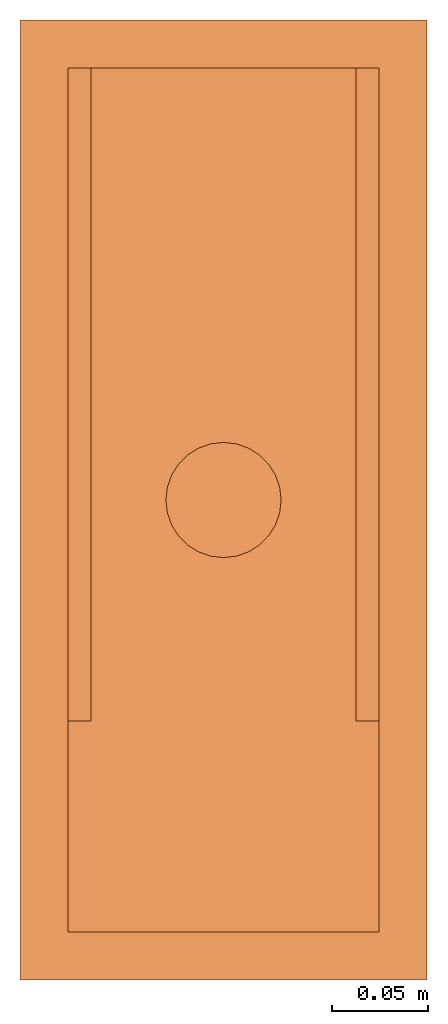
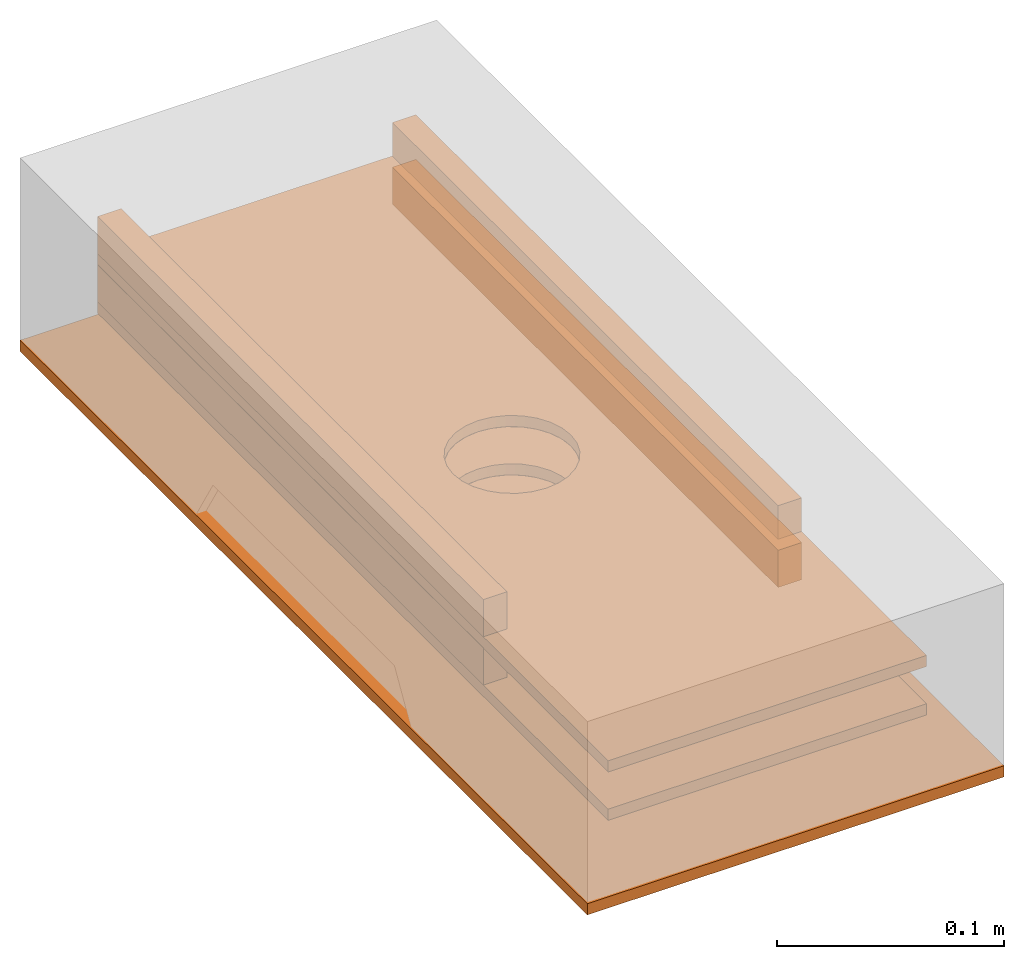
# One storey, part 1 of 2: 7 proxies.
"""IFC2X3 building model written with IfcOpenShell, lengths in millimetres."""

from ifc_helpers import new_model, si_unit, derived_unit, direction, frame, origin_with_axes, place, context, project, spatial, faceted_brep, source, transform, mapped, element, save


model = new_model("IFC2X3")

# Units and contexts
model_context = context("Model", 3, precision=1e-05, world=origin_with_axes(), true_north=direction((0.0, 1.0, 0.0)))
ifc_project = project(units=[si_unit("LENGTHUNIT", "METRE", prefix="MILLI"), si_unit("AREAUNIT", "SQUARE_METRE"), si_unit("SOLIDANGLEUNIT", "STERADIAN"), si_unit("PLANEANGLEUNIT", "RADIAN"), si_unit("TIMEUNIT", "SECOND"), si_unit("THERMODYNAMICTEMPERATUREUNIT", "DEGREE_CELSIUS"), si_unit("LUMINOUSINTENSITYUNIT", "LUMEN"), si_unit("MASSUNIT", "GRAM", prefix="KILO"), si_unit("VOLUMEUNIT", "CUBIC_METRE"), derived_unit("MASSDENSITYUNIT", [(si_unit("MASSUNIT", "GRAM", prefix="KILO"), 0), (si_unit("VOLUMEUNIT", "CUBIC_METRE"), -1)])], contexts=[model_context])

# Site, building, storey
site_placement = place(None, origin_with_axes())
site = spatial("IfcSite", under=ifc_project, at=site_placement, CompositionType="ELEMENT")
building_placement = place(site_placement, origin_with_axes())
building = spatial("IfcBuilding", under=site, at=building_placement, Name="Default Building", CompositionType="ELEMENT")
storey_placement = place(building_placement, origin_with_axes())
storey = spatial("IfcBuildingStorey", under=building, at=storey_placement, Name="Default Storey", CompositionType="ELEMENT")

# Proxies
shared_shape_1 = source(origin_with_axes(), model_context, "Body", "Brep", [
    faceted_brep([(0.0, -106.0, 0.0), (0.0, 106.0, -500.0), (0.0, 106.0, 0.0), (0.0, -106.0, -500.0), (6.0, -106.0, -500.0), (6.0, 106.0, 0.0), (6.0, 106.0, -500.0), (6.0, -106.0, 0.0)], [[[0, 1, 2]], [[1, 0, 3]], [[4, 5, 6]], [[5, 4, 7]], [[2, 6, 5]], [[6, 2, 1]], [[0, 5, 7]], [[5, 0, 2]], [[3, 7, 4]], [[7, 3, 0]], [[1, 4, 6]], [[4, 1, 3]]]),
])
proxy_1_placement = place(storey_placement, frame((1e-20, 0.0, -104.0), z_axis=(0.0, -1.0, 0.0), x_axis=(0.0, 0.0, 1.0)))
element("IfcBuildingElementProxy", 1, at=proxy_1_placement, inside=storey, ObjectType="General", context=model_context, shape_type="MappedRepresentation", body=[
    mapped(shared_shape_1, transform((0.0, 0.0, 0.0), scale=1.0)),
])
shared_shape_2 = source(origin_with_axes(), model_context, "Body", "Brep", [
    faceted_brep([(-81.0, -3.0, -225.0), (-81.0, -3.0, 225.0), (81.0, -3.0, 225.0), (81.0, -3.0, -225.0), (30.0, -3.0, 7.34788079488412e-15), (29.247837365454707, -3.0, 6.675628018689439), (27.02906603707257, -3.0, 13.01651217352675), (23.45494447404089, -3.0, 18.704694055762012), (18.704694055762, -3.0, 23.454944474040897), (13.016512173526738, -3.0, 27.029066037072578), (6.675628018689427, -3.0, 29.247837365454707), (-5.510910596163089e-15, -3.0, 30.0), (-6.675628018689437, -3.0, 29.247837365454707), (-13.016512173526749, -3.0, 27.02906603707257), (-18.704694055762012, -3.0, 23.45494447404089), (-23.454944474040904, -3.0, 18.70469405576199), (-27.029066037072575, -3.0, 13.01651217352674), (-29.24783736545471, -3.0, 6.675628018689415), (-30.0, -3.0, -3.67394039744206e-15), (-29.247837365454707, -3.0, -6.6756280186894355), (-27.02906603707257, -3.0, -13.016512173526747), (-23.45494447404089, -3.0, -18.70469405576201), (-18.704694055762005, -3.0, -23.454944474040897), (-13.016512173526742, -3.0, -27.029066037072575), (-6.67562801868943, -3.0, -29.247837365454707), (1.83697019872103e-15, -3.0, -30.0), (6.675628018689434, -3.0, -29.247837365454707), (13.016512173526745, -3.0, -27.029066037072575), (18.70469405576201, -3.0, -23.454944474040893), (23.454944474040893, -3.0, -18.704694055762005), (27.029066037072575, -3.0, -13.016512173526744), (29.247837365454707, -3.0, -6.675628018689432), (-81.0, 3.0, -225.0), (-81.0, 3.0, 225.0), (81.0, 3.0, 225.0), (81.0, 3.0, -225.0), (30.0, 3.0, 7.34788079488412e-15), (29.247837365454707, 3.0, 6.675628018689439), (27.02906603707257, 3.0, 13.01651217352675), (23.45494447404089, 3.0, 18.704694055762012), (18.704694055762, 3.0, 23.454944474040897), (13.016512173526738, 3.0, 27.029066037072578), (6.675628018689427, 3.0, 29.247837365454707), (-5.510910596163089e-15, 3.0, 30.0), (-6.675628018689437, 3.0, 29.247837365454707), (-13.016512173526749, 3.0, 27.02906603707257), (-18.704694055762012, 3.0, 23.45494447404089), (-23.454944474040904, 3.0, 18.70469405576199), (-27.029066037072575, 3.0, 13.01651217352674), (-29.24783736545471, 3.0, 6.675628018689415), (-30.0, 3.0, -3.67394039744206e-15), (-29.247837365454707, 3.0, -6.6756280186894355), (-27.02906603707257, 3.0, -13.016512173526747), (-23.45494447404089, 3.0, -18.70469405576201), (-18.704694055762005, 3.0, -23.454944474040897), (-13.016512173526742, 3.0, -27.029066037072575), (-6.67562801868943, 3.0, -29.247837365454707), (1.83697019872103e-15, 3.0, -30.0), (6.675628018689434, 3.0, -29.247837365454707), (13.016512173526745, 3.0, -27.029066037072575), (18.70469405576201, 3.0, -23.454944474040893), (23.454944474040893, 3.0, -18.704694055762005), (27.029066037072575, 3.0, -13.016512173526744), (29.247837365454707, 3.0, -6.675628018689432), (30.0, 3.0, 3.673940187178589e-15), (29.691041946411133, -3.0, 4.286857604980469), (30.0, -3.0, 3.673940187178589e-15), (29.691041946411133, 3.0, 4.286857604980469), (28.785158157348633, -3.0, 8.446757316589355), (28.785158157348633, 3.0, 8.446757316589355), (27.28719711303711, -3.0, 12.465845108032227), (27.28719711303711, 3.0, 12.465845108032227), (25.235445022583008, -3.0, 16.219356536865234), (25.235445022583008, 3.0, 16.219356536865234), (22.675521850585938, -3.0, 19.641361236572266), (22.675521850585938, 3.0, 19.641361236572266), (19.641361236572266, -3.0, 22.675521850585938), (19.641361236572266, 3.0, 22.675521850585938), (16.219356536865234, -3.0, 25.235445022583008), (16.219356536865234, 3.0, 25.235445022583008), (12.465845108032227, -3.0, 27.28719711303711), (12.465845108032227, 3.0, 27.28719711303711), (8.446757316589355, -3.0, 28.785158157348633), (8.446757316589355, 3.0, 28.785158157348633), (4.272773742675781, -3.0, 29.692628860473633), (4.272773742675781, 3.0, 29.692628860473633), (-5.510910704284357e-15, -3.0, 30.0), (-5.510910704284357e-15, 3.0, 30.0), (-4.272773742675781, -3.0, 29.692628860473633), (-4.272773742675781, 3.0, 29.692628860473633), (-8.446757316589355, -3.0, 28.785158157348633), (-8.446757316589355, 3.0, 28.785158157348633), (-12.465845108032227, -3.0, 27.28719711303711), (-12.465845108032227, 3.0, 27.28719711303711), (-16.219356536865234, -3.0, 25.235445022583008), (-16.219356536865234, 3.0, 25.235445022583008), (-19.641361236572266, -3.0, 22.675521850585938), (-19.641361236572266, 3.0, 22.675521850585938), (-22.675521850585938, -3.0, 19.641361236572266), (-22.675521850585938, 3.0, 19.641361236572266), (-25.235445022583008, -3.0, 16.219356536865234), (-25.235445022583008, 3.0, 16.219356536865234), (-27.28719711303711, -3.0, 12.465845108032227), (-27.28719711303711, 3.0, 12.465845108032227), (-28.785158157348633, -3.0, 8.446757316589355), (-28.785158157348633, 3.0, 8.446757316589355), (-29.691041946411133, -3.0, 4.286857604980469), (-29.691041946411133, 3.0, 4.286857604980469), (-30.0, -3.0, -3.673940187178589e-15), (-30.0, 3.0, -3.673940187178589e-15), (-29.691041946411133, -3.0, -4.286857604980469), (-29.691041946411133, 3.0, -4.286857604980469), (-28.785158157348633, -3.0, -8.446757316589355), (-28.785158157348633, 3.0, -8.446757316589355), (-27.28719711303711, -3.0, -12.465845108032227), (-27.28719711303711, 3.0, -12.465845108032227), (-25.235445022583008, -3.0, -16.219356536865234), (-25.235445022583008, 3.0, -16.219356536865234), (-22.675521850585938, -3.0, -19.641361236572266), (-22.675521850585938, 3.0, -19.641361236572266), (-19.641361236572266, -3.0, -22.675521850585938), (-19.641361236572266, 3.0, -22.675521850585938), (-16.219356536865234, -3.0, -25.235445022583008), (-16.219356536865234, 3.0, -25.235445022583008), (-12.465845108032227, -3.0, -27.28719711303711), (-12.465845108032227, 3.0, -27.28719711303711), (-8.446757316589355, -3.0, -28.785158157348633), (-8.446757316589355, 3.0, -28.785158157348633), (-4.272773742675781, -3.0, -29.692628860473633), (-4.272773742675781, 3.0, -29.692628860473633), (1.8369700935892946e-15, -3.0, -30.0), (1.8369700935892946e-15, 3.0, -30.0), (4.272773742675781, -3.0, -29.692628860473633), (4.272773742675781, 3.0, -29.692628860473633), (8.446757316589355, -3.0, -28.785158157348633), (8.446757316589355, 3.0, -28.785158157348633), (12.465845108032227, -3.0, -27.28719711303711), (12.465845108032227, 3.0, -27.28719711303711), (16.219356536865234, -3.0, -25.235445022583008), (16.219356536865234, 3.0, -25.235445022583008), (19.641361236572266, -3.0, -22.675521850585938), (19.641361236572266, 3.0, -22.675521850585938), (22.675521850585938, -3.0, -19.641361236572266), (22.675521850585938, 3.0, -19.641361236572266), (25.235445022583008, -3.0, -16.219356536865234), (25.235445022583008, 3.0, -16.219356536865234), (27.28719711303711, -3.0, -12.465845108032227), (27.28719711303711, 3.0, -12.465845108032227), (28.785158157348633, -3.0, -8.446757316589355), (28.785158157348633, 3.0, -8.446757316589355), (29.691041946411133, -3.0, -4.286857604980469), (29.691041946411133, 3.0, -4.286857604980469)], [[[0, 1, 2, 3], [4, 5, 6, 7, 8, 9, 10, 11, 12, 13, 14, 15, 16, 17, 18, 19, 20, 21, 22, 23, 24, 25, 26, 27, 28, 29, 30, 31]], [[32, 33, 34, 35], [36, 37, 38, 39, 40, 41, 42, 43, 44, 45, 46, 47, 48, 49, 50, 51, 52, 53, 54, 55, 56, 57, 58, 59, 60, 61, 62, 63]], [[64, 65, 66]], [[65, 64, 67]], [[67, 68, 65]], [[68, 67, 69]], [[69, 70, 68]], [[70, 69, 71]], [[71, 72, 70]], [[72, 71, 73]], [[73, 74, 72]], [[74, 73, 75]], [[75, 76, 74]], [[76, 75, 77]], [[77, 78, 76]], [[78, 77, 79]], [[79, 80, 78]], [[80, 79, 81]], [[81, 82, 80]], [[82, 81, 83]], [[83, 84, 82]], [[84, 83, 85]], [[85, 86, 84]], [[86, 85, 87]], [[87, 88, 86]], [[88, 87, 89]], [[89, 90, 88]], [[90, 89, 91]], [[91, 92, 90]], [[92, 91, 93]], [[93, 94, 92]], [[94, 93, 95]], [[95, 96, 94]], [[96, 95, 97]], [[97, 98, 96]], [[98, 97, 99]], [[99, 100, 98]], [[100, 99, 101]], [[101, 102, 100]], [[102, 101, 103]], [[103, 104, 102]], [[104, 103, 105]], [[105, 106, 104]], [[106, 105, 107]], [[107, 108, 106]], [[108, 107, 109]], [[109, 110, 108]], [[110, 109, 111]], [[111, 112, 110]], [[112, 111, 113]], [[113, 114, 112]], [[114, 113, 115]], [[115, 116, 114]], [[116, 115, 117]], [[117, 118, 116]], [[118, 117, 119]], [[119, 120, 118]], [[120, 119, 121]], [[121, 122, 120]], [[122, 121, 123]], [[123, 124, 122]], [[124, 123, 125]], [[125, 126, 124]], [[126, 125, 127]], [[127, 128, 126]], [[128, 127, 129]], [[129, 130, 128]], [[130, 129, 131]], [[131, 132, 130]], [[132, 131, 133]], [[133, 134, 132]], [[134, 133, 135]], [[135, 136, 134]], [[136, 135, 137]], [[137, 138, 136]], [[138, 137, 139]], [[139, 140, 138]], [[140, 139, 141]], [[141, 142, 140]], [[142, 141, 143]], [[143, 144, 142]], [[144, 143, 145]], [[145, 146, 144]], [[146, 145, 147]], [[147, 148, 146]], [[148, 147, 149]], [[149, 150, 148]], [[150, 149, 151]], [[151, 66, 150]], [[66, 151, 64]], [[1, 32, 33]], [[32, 1, 0]], [[2, 33, 34]], [[33, 2, 1]], [[3, 34, 35]], [[34, 3, 2]], [[0, 35, 32]], [[35, 0, 3]]]),
])
for number, where, z_axis, x_axis, name in (
    (2, (0.0, 250.0, -48.0), (0.0, -1.0, 0.0), (1.0, 0.0, 0.0), "BOARD-2"),
    (3, (0.0, 250.0, -74.0), (0.0, -1.0, 0.0), (1.0, 0.0, 0.0), "BOARD-2"),
):
    element("IfcBuildingElementProxy", number, at=place(storey_placement, frame(where, z_axis=z_axis, x_axis=x_axis)), inside=storey, Name=name, ObjectType="General", context=model_context, shape_type="MappedRepresentation", body=[
        mapped(shared_shape_2, transform((0.0, 0.0, 0.0), scale=1.0)),
    ])
shared_shape_3 = source(origin_with_axes(), model_context, "Body", "Brep", [
    faceted_brep([(0.0, -12.0, 0.0), (0.0, 0.0, -20.0), (0.0, 0.0, 0.0), (0.0, -12.0, -20.0), (340.0, -12.0, -20.0), (340.0, 0.0, 0.0), (340.0, 0.0, -20.0), (340.0, -12.0, 0.0)], [[[0, 1, 2]], [[1, 0, 3]], [[4, 5, 6]], [[5, 4, 7]], [[7, 2, 5]], [[2, 7, 0]], [[4, 0, 7]], [[0, 4, 3]], [[6, 3, 4]], [[3, 6, 1]], [[5, 1, 6]], [[1, 5, 2]]]),
])
for number, where, z_axis, x_axis, name in (
    (4, (-69.0, 475.0, -51.0), (0.0, 0.0, 1.0), (0.0, -1.0, 0.0), "02"),
    (5, (81.0, 475.0, -51.0), (0.0, 0.0, 1.0), (0.0, -1.0, 0.0), "02"),
    (6, (-81.0, 475.0, -45.0), (0.0, 0.0, -1.0), (0.0, -1.0, 0.0), "02"),
):
    element("IfcBuildingElementProxy", number, at=place(storey_placement, frame(where, z_axis=z_axis, x_axis=x_axis)), inside=storey, Name=name, ObjectType="General", context=model_context, shape_type="MappedRepresentation", body=[
        mapped(shared_shape_3, transform((0.0, 0.0, 0.0), scale=1.0)),
    ])
shared_shape_4 = source(origin_with_axes(), model_context, "Body", "Brep", [
    faceted_brep([(0.0, -12.0, 0.0), (0.0, 0.0, -18.0), (0.0, 0.0, 0.0), (0.0, -12.0, -18.0), (340.0, -12.0, -18.0), (340.0, 0.0, 0.0), (340.0, 0.0, -18.0), (340.0, -12.0, 0.0)], [[[0, 1, 2]], [[1, 0, 3]], [[4, 5, 6]], [[5, 4, 7]], [[7, 2, 5]], [[2, 7, 0]], [[4, 0, 7]], [[0, 4, 3]], [[6, 3, 4]], [[3, 6, 1]], [[5, 1, 6]], [[1, 5, 2]]]),
])
proxy_2_placement = place(storey_placement, frame((81.0, 475.0, -27.0), z_axis=(0.0, 0.0, 1.0), x_axis=(0.0, -1.0, 0.0)))
element("IfcBuildingElementProxy", 7, at=proxy_2_placement, inside=storey, Name="01", ObjectType="General", context=model_context, shape_type="MappedRepresentation", body=[
    mapped(shared_shape_4, transform((0.0, 0.0, 0.0), scale=1.0)),
])

save(model, "model.ifc")
